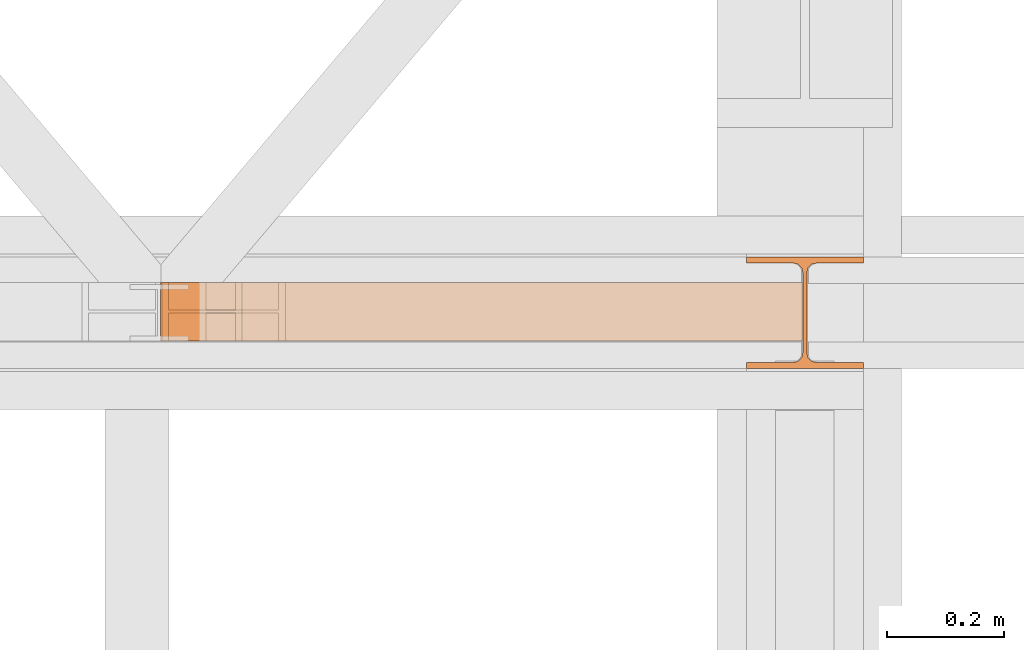
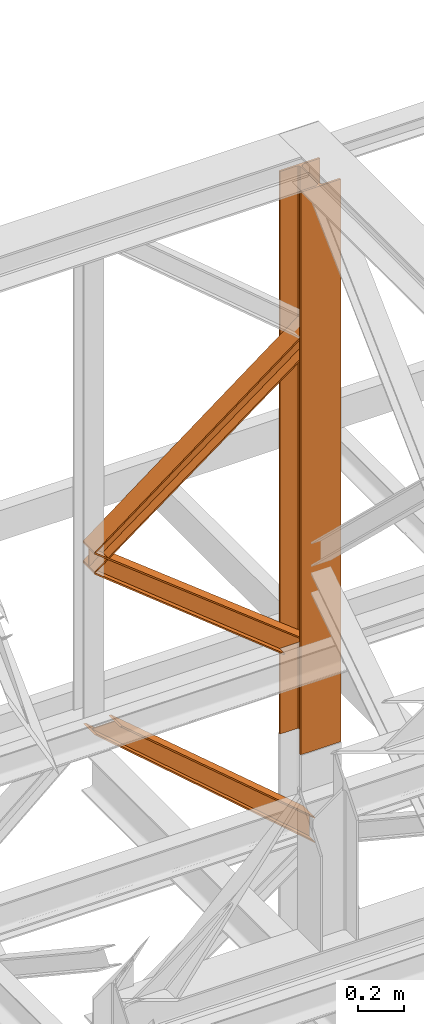
# One storey, part 128 of 208: 4 proxies.
"""IFC2X3 building model written with IfcOpenShell, lengths in millimetres."""

from ifc_helpers import new_model, entity, si_unit, converted_unit, frame, origin, origin_with_axes, place, context, subcontext, project, spatial, faceted_brep, element, save


model = new_model("IFC2X3")

# Units and contexts
model_context = context("Model", 3, precision=1e-05, world=origin())
plan_context = context("Plan", 3, precision=1e-05, world=origin())
body_context = subcontext(model_context, "Body", "Model", "MODEL_VIEW")
ifc_project = project(units=[si_unit("LENGTHUNIT", "METRE", prefix="MILLI"), converted_unit("PLANEANGLEUNIT", "DEGREE", entity("IfcPlaneAngleMeasure", 0.0174532925199433), si_unit("PLANEANGLEUNIT", "RADIAN"), dimensions=[0, 0, 0, 0, 0, 0, 0]), si_unit("AREAUNIT", "SQUARE_METRE"), si_unit("VOLUMEUNIT", "CUBIC_METRE")], contexts=[model_context, plan_context])

# Building, storey
building_placement = place(None, origin())
building = spatial("IfcBuilding", under=ifc_project, at=building_placement, CompositionType="COMPLEX")
storey_placement = place(building_placement, origin_with_axes())
storey = spatial("IfcBuildingStorey", under=building, at=storey_placement, Name="Geschoss", CompositionType="ELEMENT")

# Proxies
proxy_1_placement = place(storey_placement, frame((1092.805342082058, -13810.57439404318, 10561.56098007871), z_axis=(0.0, 0.0, 1.0), x_axis=(1.0, 0.0, 0.0)))
element("IfcBuildingElementProxy", 1, at=proxy_1_placement, inside=storey, context=body_context, shape_type="Brep", body=[
    faceted_brep([(1097.501208752581, 0.00999999999839929, 826.5831015628537), (1097.501208752582, 0.00999999999839929, 816.1419527087546), (0.0100000000009004, 0.01000000000021828, 0.01000000000203727), (0.009999999999990905, 0.01000000000021828, 9.251572776691319), (1097.501208752582, 0.00999999999839929, 816.1419527087546), (1097.50120875258, 100.0099999999984, 816.1419527087546), (0.009999999999990905, 100.0100000000002, 0.01000000000021828), (0.0100000000009004, 0.01000000000021828, 0.01000000000203727), (1097.50120875258, 100.0099999999984, 816.1419527087546), (1097.501208752581, 100.0099999999984, 826.5831015628537), (0.0100000000009004, 100.0100000000002, 9.251572776691319), (0.009999999999990905, 100.0100000000002, 0.01000000000021828), (1097.501208752581, 100.0099999999984, 826.5831015628537), (1097.501208752579, 52.5099999999984, 826.5831015628519), (0.01000000000180989, 52.51000000000022, 9.2515727766895), (0.0100000000009004, 100.0100000000002, 9.251572776691319), (1097.501208752579, 52.5099999999984, 826.5831015628519), (1097.50120875258, 52.5099999999984, 930.9945901038245), (0.0100000000009004, 52.51000000000022, 102.9431079802762), (0.01000000000180989, 52.51000000000022, 9.2515727766895), (1097.50120875258, 52.5099999999984, 930.9945901038245), (1097.501208752579, 100.0099999999984, 930.9945901038245), (0.009999999999990905, 100.0100000000002, 102.9431079802762), (0.0100000000009004, 52.51000000000022, 102.9431079802762), (1097.501208752579, 100.0099999999984, 930.9945901038245), (1097.50120875258, 100.0099999999984, 941.43573895792), (0.009999999999990905, 100.0100000000002, 112.4251816301785), (0.009999999999990905, 100.0100000000002, 102.9431079802762), (1097.50120875258, 100.0099999999984, 941.43573895792), (1097.50120875258, 0.00999999999839929, 941.43573895792), (0.0100000000009004, 0.01000000000021828, 112.4251816301803), (0.009999999999990905, 100.0100000000002, 112.4251816301785), (1097.50120875258, 0.00999999999839929, 941.43573895792), (1097.50120875258, 0.00999999999839929, 930.9945901038245), (0.0100000000009004, 0.01000000000021828, 102.9431079802762), (0.0100000000009004, 0.01000000000021828, 112.4251816301803), (1097.50120875258, 0.00999999999839929, 930.9945901038245), (1097.50120875258, 47.5099999999984, 930.9945901038245), (0.0100000000009004, 47.51000000000022, 102.943107980278), (0.0100000000009004, 0.01000000000021828, 102.9431079802762), (1097.50120875258, 47.5099999999984, 930.9945901038245), (1097.50120875258, 47.5099999999984, 826.5831015628537), (0.009999999999990905, 47.51000000000022, 9.2515727766895), (0.0100000000009004, 47.51000000000022, 102.943107980278), (1097.50120875258, 47.5099999999984, 826.5831015628537), (1097.501208752581, 0.00999999999839929, 826.5831015628537), (0.009999999999990905, 0.01000000000021828, 9.251572776691319), (0.009999999999990905, 47.51000000000022, 9.2515727766895), (1097.501208752582, 0.00999999999839929, 816.1419527087546), (1097.501208752581, 0.00999999999839929, 826.5831015628537), (1097.50120875258, 47.5099999999984, 826.5831015628537), (1097.50120875258, 47.5099999999984, 930.9945901038245), (1097.50120875258, 0.00999999999839929, 930.9945901038245), (1097.50120875258, 0.00999999999839929, 941.43573895792), (1097.50120875258, 100.0099999999984, 941.43573895792), (1097.501208752579, 100.0099999999984, 930.9945901038245), (1097.50120875258, 52.5099999999984, 930.9945901038245), (1097.501208752579, 52.5099999999984, 826.5831015628519), (1097.501208752581, 100.0099999999984, 826.5831015628537), (1097.50120875258, 100.0099999999984, 816.1419527087546), (0.0100000000009004, 0.01000000000021828, 0.01000000000203727), (0.009999999999990905, 100.0100000000002, 0.01000000000021828), (0.0100000000009004, 100.0100000000002, 9.251572776691319), (0.01000000000180989, 52.51000000000022, 9.2515727766895), (0.0100000000009004, 52.51000000000022, 102.9431079802762), (0.009999999999990905, 100.0100000000002, 102.9431079802762), (0.009999999999990905, 100.0100000000002, 112.4251816301785), (0.0100000000009004, 0.01000000000021828, 112.4251816301803), (0.0100000000009004, 0.01000000000021828, 102.9431079802762), (0.0100000000009004, 47.51000000000022, 102.943107980278), (0.009999999999990905, 47.51000000000022, 9.2515727766895), (0.009999999999990905, 0.01000000000021828, 9.251572776691319)], [[[0, 1, 2, 3]], [[4, 5, 6, 7]], [[8, 9, 10, 11]], [[12, 13, 14, 15]], [[16, 17, 18, 19]], [[20, 21, 22, 23]], [[24, 25, 26, 27]], [[28, 29, 30, 31]], [[32, 33, 34, 35]], [[36, 37, 38, 39]], [[40, 41, 42, 43]], [[44, 45, 46, 47]], [[48, 49, 50, 51, 52, 53, 54, 55, 56, 57, 58, 59]], [[60, 61, 62, 63, 64, 65, 66, 67, 68, 69, 70, 71]]], orient=[[False], [False], [False], [False], [False], [False], [False], [False], [False], [False], [False], [False], [False], [False]]),
])
proxy_2_placement = place(storey_placement, frame((1092.805342082057, -13810.57439404318, 9806.105713222343), z_axis=(0.0, 0.0, 1.0), x_axis=(1.0, 0.0, 0.0)))
element("IfcBuildingElementProxy", 2, at=proxy_2_placement, inside=storey, context=body_context, shape_type="Brep", body=[
    faceted_brep([(1103.709626513662, 0.01000000000021828, 0.01000000000021828), (1094.286249076172, 0.01000000000021828, 0.00999999999839929), (0.009999999999990905, 0.01000000000021828, 858.1978834278525), (0.009999999999990905, 0.01000000000021828, 867.8804484865395), (1103.709626513662, 100.0100000000002, 0.01000000000021828), (1103.709626513662, 0.01000000000021828, 0.01000000000021828), (0.009999999999990905, 0.01000000000021828, 867.8804484865395), (0.009999999999990905, 100.0100000000002, 867.8804484865414), (1094.286249076172, 100.0100000000002, 0.00999999999839929), (1103.709626513662, 100.0100000000002, 0.01000000000021828), (0.009999999999990905, 100.0100000000002, 867.8804484865414), (0.009999999999990905, 100.0100000000002, 858.1978834278525), (1094.286249076172, 52.51000000000022, 0.00999999999839929), (1094.286249076172, 100.0100000000002, 0.00999999999839929), (0.009999999999990905, 100.0100000000002, 858.1978834278525), (0.009999999999990905, 52.51000000000022, 858.1978834278525), (950.0524747012457, 52.51000000000022, 0.01000000000021828), (1094.286249076172, 52.51000000000022, 0.00999999999839929), (0.009999999999990905, 52.51000000000022, 858.1978834278525), (0.009999999999990905, 52.51000000000022, 761.3722328409858), (950.0524747012494, 100.0100000000002, 0.01000000000021828), (950.0524747012457, 52.51000000000022, 0.01000000000021828), (0.009999999999990905, 52.51000000000022, 761.3722328409858), (0.009999999999990905, 100.0100000000002, 761.3722328409858), (940.6290972637569, 100.0100000000002, 0.01000000000021828), (950.0524747012494, 100.0100000000002, 0.01000000000021828), (0.009999999999990905, 100.0100000000002, 761.3722328409858), (0.009999999999990905, 100.0100000000002, 751.6896677822988), (940.6290972637532, 0.01000000000021828, 0.01000000000021828), (940.6290972637569, 100.0100000000002, 0.01000000000021828), (0.009999999999990905, 100.0100000000002, 751.6896677822988), (0.009999999999990905, 0.01000000000021828, 751.6896677822988), (950.0524747012494, 0.01000000000021828, 0.01000000000021828), (940.6290972637532, 0.01000000000021828, 0.01000000000021828), (0.009999999999990905, 0.01000000000021828, 751.6896677822988), (0.009999999999990905, 0.01000000000021828, 761.3722328409858), (950.0524747012512, 47.51000000000022, 0.01000000000203727), (950.0524747012494, 0.01000000000021828, 0.01000000000021828), (0.009999999999990905, 0.01000000000021828, 761.3722328409858), (0.009999999999990905, 47.51000000000022, 761.3722328409858), (1094.286249076172, 47.51000000000022, 0.00999999999839929), (950.0524747012512, 47.51000000000022, 0.01000000000203727), (0.009999999999990905, 47.51000000000022, 761.3722328409858), (0.009999999999990905, 47.51000000000022, 858.1978834278525), (1094.286249076172, 0.01000000000021828, 0.00999999999839929), (1094.286249076172, 47.51000000000022, 0.00999999999839929), (0.009999999999990905, 47.51000000000022, 858.1978834278525), (0.009999999999990905, 0.01000000000021828, 858.1978834278525), (0.009999999999990905, 0.01000000000021828, 867.8804484865395), (0.009999999999990905, 0.01000000000021828, 858.1978834278525), (0.009999999999990905, 47.51000000000022, 858.1978834278525), (0.009999999999990905, 47.51000000000022, 761.3722328409858), (0.009999999999990905, 0.01000000000021828, 761.3722328409858), (0.009999999999990905, 0.01000000000021828, 751.6896677822988), (0.009999999999990905, 100.0100000000002, 751.6896677822988), (0.009999999999990905, 100.0100000000002, 761.3722328409858), (0.009999999999990905, 52.51000000000022, 761.3722328409858), (0.009999999999990905, 52.51000000000022, 858.1978834278525), (0.009999999999990905, 100.0100000000002, 858.1978834278525), (0.009999999999990905, 100.0100000000002, 867.8804484865414), (1094.286249076172, 0.01000000000021828, 0.00999999999839929), (1103.709626513662, 0.01000000000021828, 0.01000000000021828), (1103.709626513662, 100.0100000000002, 0.01000000000021828), (1094.286249076172, 100.0100000000002, 0.00999999999839929), (1094.286249076172, 52.51000000000022, 0.00999999999839929), (950.0524747012457, 52.51000000000022, 0.01000000000021828), (950.0524747012494, 100.0100000000002, 0.01000000000021828), (940.6290972637569, 100.0100000000002, 0.01000000000021828), (940.6290972637532, 0.01000000000021828, 0.01000000000021828), (950.0524747012494, 0.01000000000021828, 0.01000000000021828), (950.0524747012512, 47.51000000000022, 0.01000000000203727), (1094.286249076172, 47.51000000000022, 0.00999999999839929)], [[[0, 1, 2, 3]], [[4, 5, 6, 7]], [[8, 9, 10, 11]], [[12, 13, 14, 15]], [[16, 17, 18, 19]], [[20, 21, 22, 23]], [[24, 25, 26, 27]], [[28, 29, 30, 31]], [[32, 33, 34, 35]], [[36, 37, 38, 39]], [[40, 41, 42, 43]], [[44, 45, 46, 47]], [[48, 49, 50, 51, 52, 53, 54, 55, 56, 57, 58, 59]], [[60, 61, 62, 63, 64, 65, 66, 67, 68, 69, 70, 71]]], orient=[[False], [False], [False], [False], [False], [False], [False], [False], [False], [False], [False], [False], [False], [False]]),
])
proxy_3_placement = place(storey_placement, frame((1095.036077463241, -13810.57439404318, 8758.997679309408), z_axis=(0.0, 0.0, 1.0), x_axis=(1.0, 0.0, 0.0)))
element("IfcBuildingElementProxy", 3, at=proxy_3_placement, inside=storey, context=body_context, shape_type="Brep", body=[
    faceted_brep([(1094.978890998369, 0.01000000000021828, 127.7973220590939), (125.4343434663467, 0.01000000000021828, 951.1180339129351), (136.6429846423714, 0.01000000000021828, 951.1180339129332), (1094.978890998369, 0.01000000000021828, 136.1625718196283), (1094.978890998369, 0.01000000000021828, 136.1625718196283), (136.6429846423714, 0.01000000000021828, 951.1180339129332), (136.6429846423732, 100.0100000000002, 951.1180339129332), (1094.978890998369, 100.0100000000002, 136.1625718196283), (1094.978890998369, 100.0100000000002, 136.1625718196283), (136.6429846423732, 100.0100000000002, 951.1180339129332), (125.4343434663467, 100.0100000000002, 951.1180339129351), (1094.978890998369, 100.0100000000002, 127.7973220590939), (1094.978890998369, 100.0100000000002, 127.7973220590939), (125.4343434663467, 100.0100000000002, 951.1180339129351), (125.4343434663476, 52.51000000000022, 951.1180339129332), (1094.978890998369, 52.51000000000022, 127.7973220590939), (1094.978890998369, 52.51000000000022, 127.7973220590939), (125.4343434663476, 52.51000000000022, 951.1180339129332), (11.14167617186445, 52.51000000000022, 951.1180339129351), (1094.978890998369, 52.51000000000022, 8.373726266809172), (1094.978890998369, 52.51000000000022, 8.373726266809172), (11.14167617186445, 52.51000000000022, 951.1180339129351), (11.14167617186445, 100.0100000000002, 951.1180339129351), (1094.978890998369, 100.0100000000002, 8.37372626681281), (1094.978890998369, 100.0100000000002, 8.37372626681281), (11.14167617186445, 100.0100000000002, 951.1180339129351), (0.009999999999990905, 100.0100000000002, 951.1180339129369), (1094.978890998369, 100.0100000000002, 0.01000000000203727), (1094.978890998369, 100.0100000000002, 0.01000000000203727), (0.009999999999990905, 100.0100000000002, 951.1180339129369), (0.009999999999990905, 0.01000000000021828, 951.1180339129369), (1094.978890998369, 0.01000000000021828, 0.01000000000021828), (1094.978890998369, 0.01000000000021828, 0.01000000000021828), (0.009999999999990905, 0.01000000000021828, 951.1180339129369), (11.14167617186445, 0.01000000000021828, 951.1180339129351), (1094.978890998369, 0.01000000000021828, 8.37372626681281), (1094.978890998369, 0.01000000000021828, 8.37372626681281), (11.14167617186445, 0.01000000000021828, 951.1180339129351), (11.14167617186536, 47.51000000000022, 951.1180339129351), (1094.978890998369, 47.51000000000022, 8.373726266816448), (1094.978890998369, 47.51000000000022, 8.373726266816448), (11.14167617186536, 47.51000000000022, 951.1180339129351), (125.4343434663467, 47.51000000000022, 951.1180339129351), (1094.978890998369, 47.51000000000022, 127.7973220590939), (1094.978890998369, 47.51000000000022, 127.7973220590939), (125.4343434663467, 47.51000000000022, 951.1180339129351), (125.4343434663467, 0.01000000000021828, 951.1180339129351), (1094.978890998369, 0.01000000000021828, 127.7973220590939), (125.4343434663467, 0.01000000000021828, 951.1180339129351), (125.4343434663467, 47.51000000000022, 951.1180339129351), (11.14167617186536, 47.51000000000022, 951.1180339129351), (11.14167617186445, 0.01000000000021828, 951.1180339129351), (0.009999999999990905, 0.01000000000021828, 951.1180339129369), (0.009999999999990905, 100.0100000000002, 951.1180339129369), (11.14167617186445, 100.0100000000002, 951.1180339129351), (11.14167617186445, 52.51000000000022, 951.1180339129351), (125.4343434663476, 52.51000000000022, 951.1180339129332), (125.4343434663467, 100.0100000000002, 951.1180339129351), (136.6429846423732, 100.0100000000002, 951.1180339129332), (136.6429846423714, 0.01000000000021828, 951.1180339129332), (1094.978890998369, 0.01000000000021828, 136.1625718196283), (1094.978890998369, 100.0100000000002, 136.1625718196283), (1094.978890998369, 100.0100000000002, 127.7973220590939), (1094.978890998369, 52.51000000000022, 127.7973220590939), (1094.978890998369, 52.51000000000022, 8.373726266809172), (1094.978890998369, 100.0100000000002, 8.37372626681281), (1094.978890998369, 100.0100000000002, 0.01000000000203727), (1094.978890998369, 0.01000000000021828, 0.01000000000021828), (1094.978890998369, 0.01000000000021828, 8.37372626681281), (1094.978890998369, 47.51000000000022, 8.373726266816448), (1094.978890998369, 47.51000000000022, 127.7973220590939), (1094.978890998369, 0.01000000000021828, 127.7973220590939)], [[[0, 1, 2, 3]], [[4, 5, 6, 7]], [[8, 9, 10, 11]], [[12, 13, 14, 15]], [[16, 17, 18, 19]], [[20, 21, 22, 23]], [[24, 25, 26, 27]], [[28, 29, 30, 31]], [[32, 33, 34, 35]], [[36, 37, 38, 39]], [[40, 41, 42, 43]], [[44, 45, 46, 47]], [[48, 49, 50, 51, 52, 53, 54, 55, 56, 57, 58, 59]], [[60, 61, 62, 63, 64, 65, 66, 67, 68, 69, 70, 71]]], orient=[[False], [False], [False], [False], [False], [False], [False], [False], [False], [False], [False], [False], [False], [False]]),
])
proxy_4_placement = place(storey_placement, frame((2093.254967038549, -13857.57439657637, 9284.990005364414), z_axis=(0.0, 0.0, 1.0), x_axis=(1.0, 0.0, 0.0)))
element("IfcBuildingElementProxy", 4, at=proxy_4_placement, inside=storey, context=body_context, shape_type="Brep", body=[
    faceted_brep([(0.01000000000021828, 190.0100125169756, 2965.010053329394), (200.0100029802325, 190.0100125169756, 2965.010053329394), (200.0100029802325, 180.0100146031382, 2965.010053329394), (121.2600035762789, 180.0100071525576, 2965.010053329394), (111.9441915473344, 178.1454621052744, 2965.010053329394), (105.1245498640838, 171.3258190250399, 2965.010053329394), (103.2600015571716, 162.010007927418, 2965.010053329394), (103.2600015571716, 28.00999713897727, 2965.010053329394), (105.1245498640838, 18.69418604135535, 2965.010053329394), (111.9441915473344, 11.87454296112082, 2965.010053329394), (121.2600035762789, 10.00999791383765, 2965.010053329394), (200.0100029802325, 10.00999791383765, 2965.010053329394), (200.0100029802325, 0.01000000000021828, 2965.010053329394), (0.01000000000021828, 0.01000000000021828, 2965.010053329394), (0.01000000000021828, 10.00999791383765, 2965.010053329394), (78.75999940395377, 10.00999791383765, 2965.010053329394), (88.07581143289826, 11.87454296112082, 2965.010053329394), (94.89545311614893, 18.69418604135535, 2965.010053329394), (96.76000142306111, 28.00999713897727, 2965.010053329394), (96.76000142306111, 162.010007927418, 2965.010053329394), (94.89545311614893, 171.3258190250399, 2965.010053329394), (88.07581143289826, 178.1454621052744, 2965.010053329394), (78.75999940395377, 180.0100071525576, 2965.010053329394), (0.01000000000021828, 180.0100146031382, 2965.010053329394), (200.0100029802325, 190.0100125169756, 2965.010053329394), (0.01000000000021828, 190.0100125169756, 2965.010053329394), (0.01000000000021828, 190.0100125169756, 0.01000000000021828), (200.0100029802325, 190.0100125169756, 0.01000000000021828), (200.0100029802325, 180.0100146031382, 2965.010053329394), (200.0100029802325, 190.0100125169756, 2965.010053329394), (200.0100029802325, 190.0100125169756, 0.01000000000021828), (200.0100029802325, 180.0100146031382, 0.01000000000021828), (121.2600035762789, 180.0100071525576, 2965.010053329394), (200.0100029802325, 180.0100146031382, 2965.010053329394), (200.0100029802325, 180.0100146031382, 0.01000000000021828), (121.2600035762789, 180.0100071525576, 0.01000000000021828), (111.9441915473344, 178.1454621052744, 2965.010053329394), (121.2600035762789, 180.0100071525576, 2965.010053329394), (121.2600035762789, 180.0100071525576, 0.01000000000021828), (111.9441915473344, 178.1454621052744, 0.01000000000021828), (105.1245498640838, 171.3258190250399, 2965.010053329394), (111.9441915473344, 178.1454621052744, 2965.010053329394), (111.9441915473344, 178.1454621052744, 0.01000000000021828), (105.1245498640838, 171.3258190250399, 0.01000000000021828), (103.2600015571716, 162.010007927418, 2965.010053329394), (105.1245498640838, 171.3258190250399, 2965.010053329394), (105.1245498640838, 171.3258190250399, 0.01000000000021828), (103.2600015571716, 162.010007927418, 0.01000000000021828), (103.2600015571716, 28.00999713897727, 2965.010053329394), (103.2600015571716, 162.010007927418, 2965.010053329394), (103.2600015571716, 162.010007927418, 0.01000000000021828), (103.2600015571716, 28.00999713897727, 0.01000000000021828), (105.1245498640838, 18.69418604135535, 2965.010053329394), (103.2600015571716, 28.00999713897727, 2965.010053329394), (103.2600015571716, 28.00999713897727, 0.01000000000021828), (105.1245498640838, 18.69418604135535, 0.01000000000021828), (111.9441915473344, 11.87454296112082, 2965.010053329394), (105.1245498640838, 18.69418604135535, 2965.010053329394), (105.1245498640838, 18.69418604135535, 0.01000000000021828), (111.9441915473344, 11.87454296112082, 0.01000000000021828), (121.2600035762789, 10.00999791383765, 2965.010053329394), (111.9441915473344, 11.87454296112082, 2965.010053329394), (111.9441915473344, 11.87454296112082, 0.01000000000021828), (121.2600035762789, 10.00999791383765, 0.01000000000021828), (200.0100029802325, 10.00999791383765, 2965.010053329394), (121.2600035762789, 10.00999791383765, 2965.010053329394), (121.2600035762789, 10.00999791383765, 0.01000000000021828), (200.0100029802325, 10.00999791383765, 0.01000000000021828), (200.0100029802325, 0.01000000000021828, 2965.010053329394), (200.0100029802325, 10.00999791383765, 2965.010053329394), (200.0100029802325, 10.00999791383765, 0.01000000000021828), (200.0100029802325, 0.01000000000021828, 0.01000000000021828), (0.01000000000021828, 0.01000000000021828, 2965.010053329394), (200.0100029802325, 0.01000000000021828, 2965.010053329394), (200.0100029802325, 0.01000000000021828, 0.01000000000021828), (0.01000000000021828, 0.01000000000021828, 0.01000000000021828), (0.01000000000021828, 10.00999791383765, 2965.010053329394), (0.01000000000021828, 0.01000000000021828, 2965.010053329394), (0.01000000000021828, 0.01000000000021828, 0.01000000000021828), (0.01000000000021828, 10.00999791383765, 0.01000000000021828), (78.75999940395377, 10.00999791383765, 2965.010053329394), (0.01000000000021828, 10.00999791383765, 2965.010053329394), (0.01000000000021828, 10.00999791383765, 0.01000000000021828), (78.75999940395377, 10.00999791383765, 0.01000000000021828), (88.07581143289826, 11.87454296112082, 2965.010053329394), (78.75999940395377, 10.00999791383765, 2965.010053329394), (78.75999940395377, 10.00999791383765, 0.01000000000021828), (88.07581143289826, 11.87454296112082, 0.01000000000021828), (94.89545311614893, 18.69418604135535, 2965.010053329394), (88.07581143289826, 11.87454296112082, 2965.010053329394), (88.07581143289826, 11.87454296112082, 0.01000000000021828), (94.89545311614893, 18.69418604135535, 0.01000000000021828), (96.76000142306111, 28.00999713897727, 2965.010053329394), (94.89545311614893, 18.69418604135535, 2965.010053329394), (94.89545311614893, 18.69418604135535, 0.01000000000021828), (96.76000142306111, 28.00999713897727, 0.01000000000021828), (96.76000142306111, 162.010007927418, 2965.010053329394), (96.76000142306111, 28.00999713897727, 2965.010053329394), (96.76000142306111, 28.00999713897727, 0.01000000000021828), (96.76000142306111, 162.010007927418, 0.01000000000021828), (94.89545311614893, 171.3258190250399, 2965.010053329394), (96.76000142306111, 162.010007927418, 2965.010053329394), (96.76000142306111, 162.010007927418, 0.01000000000021828), (94.89545311614893, 171.3258190250399, 0.01000000000021828), (88.07581143289826, 178.1454621052744, 2965.010053329394), (94.89545311614893, 171.3258190250399, 2965.010053329394), (94.89545311614893, 171.3258190250399, 0.01000000000021828), (88.07581143289826, 178.1454621052744, 0.01000000000021828), (78.75999940395377, 180.0100071525576, 2965.010053329394), (88.07581143289826, 178.1454621052744, 2965.010053329394), (88.07581143289826, 178.1454621052744, 0.01000000000021828), (78.75999940395377, 180.0100071525576, 0.01000000000021828), (0.01000000000021828, 180.0100146031382, 2965.010053329394), (78.75999940395377, 180.0100071525576, 2965.010053329394), (78.75999940395377, 180.0100071525576, 0.01000000000021828), (0.01000000000021828, 180.0100146031382, 0.01000000000021828), (0.01000000000021828, 190.0100125169756, 2965.010053329394), (0.01000000000021828, 180.0100146031382, 2965.010053329394), (0.01000000000021828, 180.0100146031382, 0.01000000000021828), (0.01000000000021828, 190.0100125169756, 0.01000000000021828), (0.01000000000021828, 190.0100125169756, 0.01000000000021828), (0.01000000000021828, 180.0100146031382, 0.01000000000021828), (78.75999940395377, 180.0100071525576, 0.01000000000021828), (88.07581143289826, 178.1454621052744, 0.01000000000021828), (94.89545311614893, 171.3258190250399, 0.01000000000021828), (96.76000142306111, 162.010007927418, 0.01000000000021828), (96.76000142306111, 28.00999713897727, 0.01000000000021828), (94.89545311614893, 18.69418604135535, 0.01000000000021828), (88.07581143289826, 11.87454296112082, 0.01000000000021828), (78.75999940395377, 10.00999791383765, 0.01000000000021828), (0.01000000000021828, 10.00999791383765, 0.01000000000021828), (0.01000000000021828, 0.01000000000021828, 0.01000000000021828), (200.0100029802325, 0.01000000000021828, 0.01000000000021828), (200.0100029802325, 10.00999791383765, 0.01000000000021828), (121.2600035762789, 10.00999791383765, 0.01000000000021828), (111.9441915473344, 11.87454296112082, 0.01000000000021828), (105.1245498640838, 18.69418604135535, 0.01000000000021828), (103.2600015571716, 28.00999713897727, 0.01000000000021828), (103.2600015571716, 162.010007927418, 0.01000000000021828), (105.1245498640838, 171.3258190250399, 0.01000000000021828), (111.9441915473344, 178.1454621052744, 0.01000000000021828), (121.2600035762789, 180.0100071525576, 0.01000000000021828), (200.0100029802325, 180.0100146031382, 0.01000000000021828), (200.0100029802325, 190.0100125169756, 0.01000000000021828)], [[[0, 1, 2, 3, 4, 5, 6, 7, 8, 9, 10, 11, 12, 13, 14, 15, 16, 17, 18, 19, 20, 21, 22, 23]], [[24, 25, 26, 27]], [[28, 29, 30, 31]], [[32, 33, 34, 35]], [[36, 37, 38, 39]], [[40, 41, 42, 43]], [[44, 45, 46, 47]], [[48, 49, 50, 51]], [[52, 53, 54, 55]], [[56, 57, 58, 59]], [[60, 61, 62, 63]], [[64, 65, 66, 67]], [[68, 69, 70, 71]], [[72, 73, 74, 75]], [[76, 77, 78, 79]], [[80, 81, 82, 83]], [[84, 85, 86, 87]], [[88, 89, 90, 91]], [[92, 93, 94, 95]], [[96, 97, 98, 99]], [[100, 101, 102, 103]], [[104, 105, 106, 107]], [[108, 109, 110, 111]], [[112, 113, 114, 115]], [[116, 117, 118, 119]], [[120, 121, 122, 123, 124, 125, 126, 127, 128, 129, 130, 131, 132, 133, 134, 135, 136, 137, 138, 139, 140, 141, 142, 143]]], orient=[[False], [False], [False], [False], [False], [False], [False], [False], [False], [False], [False], [False], [False], [False], [False], [False], [False], [False], [False], [False], [False], [False], [False], [False], [False], [False]]),
])

save(model, "model.ifc")
